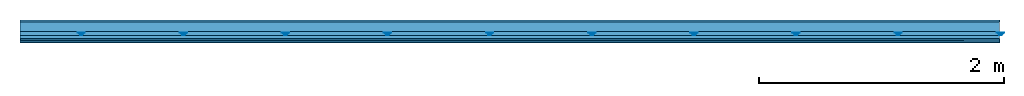
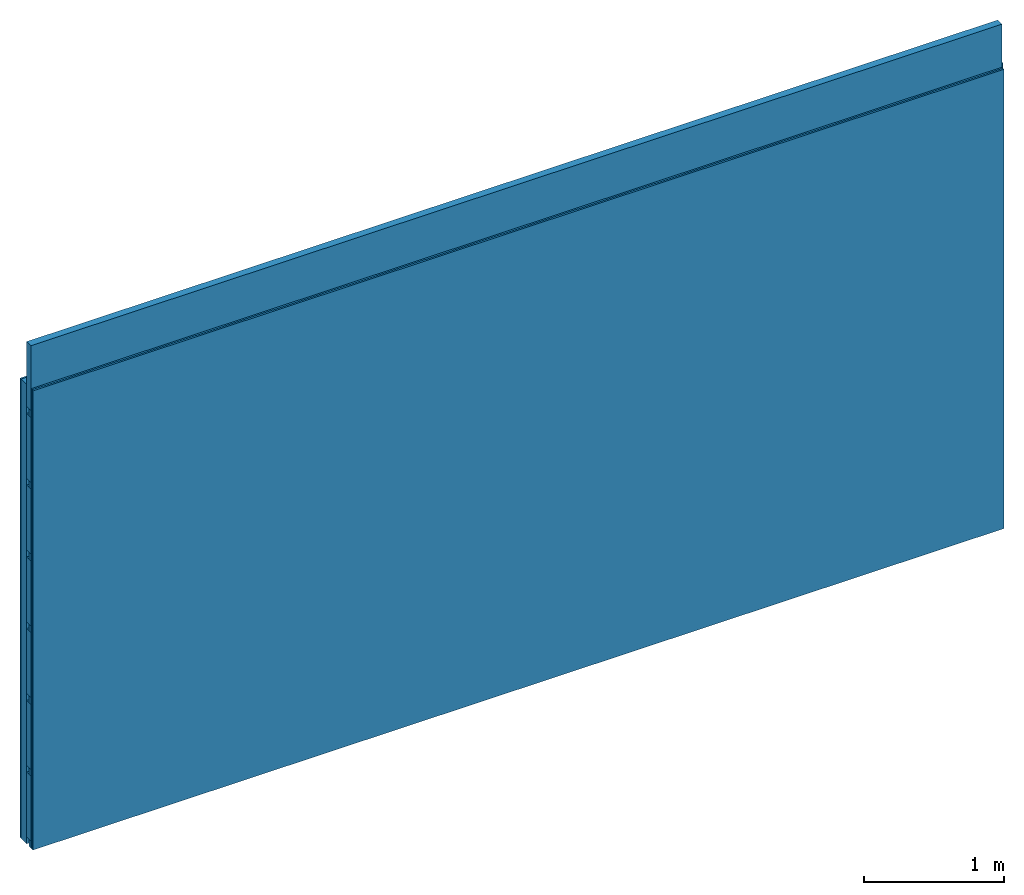
# One storey: 4 members, 3 plates, 1 element without a shape of its own.
"""IFC4 building model written with IfcOpenShell, lengths in metres."""

from ifc_helpers import new_model, si_unit, derived_unit, direction, frame, frame_2d, origin, origin_with_axes, place, context, project, spatial, polyline, rectangle, outline, extrude, material, layer, layer_set, type_object, element, aggregate, save


model = new_model("IFC4")

# Units and contexts
plan_context = context("Plan", 3, precision=1e-05, world=origin(), true_north=direction((0.0, 1.0)))
model_context = context("Model", 3, precision=1e-05, world=origin(), true_north=direction((0.0, 1.0)))
ifc_project = project(units=[si_unit("LENGTHUNIT", "METRE"), derived_unit("SOUNDPRESSUREUNIT", [(si_unit("PRESSUREUNIT", "PASCAL", prefix="MICRO"), 0)]), si_unit("ENERGYUNIT", "JOULE", prefix="MEGA"), si_unit("MASSUNIT", "GRAM", prefix="KILO"), derived_unit("THERMALTRANSMITTANCEUNIT", [(si_unit("POWERUNIT", "WATT"), 1), (si_unit("AREAUNIT", "SQUARE_METRE"), -1), (si_unit("THERMODYNAMICTEMPERATUREUNIT", "KELVIN"), -1)]), derived_unit("AREADENSITYUNIT", [(si_unit("MASSUNIT", "GRAM", prefix="KILO"), 1), (si_unit("AREAUNIT", "SQUARE_METRE"), -1)]), derived_unit("USERDEFINED", [(si_unit("ENERGYUNIT", "JOULE", prefix="MEGA"), 1), (si_unit("AREAUNIT", "SQUARE_METRE"), -1)])], contexts=[plan_context, model_context])

# Site, building, storey
site = spatial("IfcSite", under=ifc_project)
building_placement = place(None, origin())
building = spatial("IfcBuilding", under=site, at=building_placement)
storey_placement = place(building_placement, origin())
storey = spatial("IfcBuildingStorey", under=building, at=storey_placement)

# Wall, members, plates
ifc_material_1 = material(Name="Glued joints")
ifc_layer_1 = layer(ifc_material_1, 0.0, Name="Surface")
ifc_material_2 = material(Category="03.007")
ifc_layer_2 = layer(ifc_material_2, 0.015, Name="1st layer")
ifc_material_3 = material(Name="of the art")
ifc_layer_3 = layer(ifc_material_3, 0.0, Name="Bond")
ifc_layer_4 = layer(None, 0.08, Name="Support")
ifc_material_4 = material(Name="no composite action")
ifc_layer_5 = layer(ifc_material_4, 0.0, Name="Bond")
ifc_layer_6 = layer(None, 0.03, Name="Coupling")
ifc_layer_7 = layer(None, 0.03, Name="Battens / profiles")
ifc_material_5 = material(Name="Plasterboard type A", Category="03.008")
ifc_layer_8 = layer(ifc_material_5, 0.015, Name="Covering 1st layer")
ifc_layer_9 = layer(ifc_material_5, 0.015, Name="Covering 2nd layer")
ifc_material_6 = material(Name="joints", Category="04.017")
ifc_layer_10 = layer(ifc_material_6, 0.0, Name="Surface")
ifc_layer_set = layer_set([ifc_layer_1, ifc_layer_2, ifc_layer_3, ifc_layer_4, ifc_layer_5, ifc_layer_6, ifc_layer_7, ifc_layer_8, ifc_layer_9, ifc_layer_10])
wall_type = type_object("IfcWallType", Name="C0114", PredefinedType="NOTDEFINED", material=ifc_layer_set)
wall_placement = place(None, frame((0.0, 0.0, 0.0), z_axis=(0.0, -1.0, 0.0), x_axis=(1.0, 0.0, 0.0)))
wall = element("IfcWall", 1, at=wall_placement, inside=storey, type_object=wall_type, material=ifc_layer_set, Name="Wall #1")
ifc_material_7 = material()
member_1_placement = place(wall_placement, origin())
member_1 = element("IfcMember", 2, at=member_1_placement, material=ifc_material_7, Name="Support", context=plan_context, shape_type="SweptSolid", body=[
    extrude(rectangle(XDim=1.0, YDim=0.08, at=frame_2d((0.5, 0.04), x_axis=(1.0, 0.0))), frame((0.0, 4.0, 0.015), z_axis=(0.0, -1.0, 0.0), x_axis=(1.0, 0.0, 0.0)), (0.0, 0.0, 1.0), 4.0),
    extrude(rectangle(XDim=1.0, YDim=0.08, at=frame_2d((0.5, 0.04), x_axis=(1.0, 0.0))), frame((1.0, 4.0, 0.015), z_axis=(0.0, -1.0, 0.0), x_axis=(1.0, 0.0, 0.0)), (0.0, 0.0, 1.0), 4.0),
    extrude(rectangle(XDim=1.0, YDim=0.08, at=frame_2d((0.5, 0.04), x_axis=(1.0, 0.0))), frame((2.0, 4.0, 0.015), z_axis=(0.0, -1.0, 0.0), x_axis=(1.0, 0.0, 0.0)), (0.0, 0.0, 1.0), 4.0),
    extrude(rectangle(XDim=1.0, YDim=0.08, at=frame_2d((0.5, 0.04), x_axis=(1.0, 0.0))), frame((3.0, 4.0, 0.015), z_axis=(0.0, -1.0, 0.0), x_axis=(1.0, 0.0, 0.0)), (0.0, 0.0, 1.0), 4.0),
    extrude(rectangle(XDim=1.0, YDim=0.08, at=frame_2d((0.5, 0.04), x_axis=(1.0, 0.0))), frame((4.0, 4.0, 0.015), z_axis=(0.0, -1.0, 0.0), x_axis=(1.0, 0.0, 0.0)), (0.0, 0.0, 1.0), 4.0),
    extrude(rectangle(XDim=1.0, YDim=0.08, at=frame_2d((0.5, 0.04), x_axis=(1.0, 0.0))), frame((5.0, 4.0, 0.015), z_axis=(0.0, -1.0, 0.0), x_axis=(1.0, 0.0, 0.0)), (0.0, 0.0, 1.0), 4.0),
    extrude(rectangle(XDim=1.0, YDim=0.08, at=frame_2d((0.5, 0.04), x_axis=(1.0, 0.0))), frame((6.0, 4.0, 0.015), z_axis=(0.0, -1.0, 0.0), x_axis=(1.0, 0.0, 0.0)), (0.0, 0.0, 1.0), 4.0),
    extrude(rectangle(XDim=1.0, YDim=0.08, at=frame_2d((0.5, 0.04), x_axis=(1.0, 0.0))), frame((7.0, 4.0, 0.015), z_axis=(0.0, -1.0, 0.0), x_axis=(1.0, 0.0, 0.0)), (0.0, 0.0, 1.0), 4.0),
])
ifc_material_8 = material()
member_2_placement = place(wall_placement, origin())
member_2 = element("IfcMember", 3, at=member_2_placement, material=ifc_material_8, Name="Coupling", context=plan_context, shape_type="SweptSolid", body=[
    extrude(outline(polyline([(0.0, 0.0), (0.06, 0.0), (0.04, 0.02), (0.02, 0.02), (0.0, 0.0)])), frame((0.47, 4.0, 0.105), z_axis=(0.0, -1.0, 0.0), x_axis=(1.0, 0.0, 0.0)), (0.0, 0.0, 1.0), 4.0),
    extrude(outline(polyline([(0.0, 0.0), (0.06, 0.0), (0.04, 0.02), (0.02, 0.02), (0.0, 0.0)])), frame((1.304, 4.0, 0.105), z_axis=(0.0, -1.0, 0.0), x_axis=(1.0, 0.0, 0.0)), (0.0, 0.0, 1.0), 4.0),
    extrude(outline(polyline([(0.0, 0.0), (0.06, 0.0), (0.04, 0.02), (0.02, 0.02), (0.0, 0.0)])), frame((2.138, 4.0, 0.105), z_axis=(0.0, -1.0, 0.0), x_axis=(1.0, 0.0, 0.0)), (0.0, 0.0, 1.0), 4.0),
    extrude(outline(polyline([(0.0, 0.0), (0.06, 0.0), (0.04, 0.02), (0.02, 0.02), (0.0, 0.0)])), frame((2.972, 4.0, 0.105), z_axis=(0.0, -1.0, 0.0), x_axis=(1.0, 0.0, 0.0)), (0.0, 0.0, 1.0), 4.0),
    extrude(outline(polyline([(0.0, 0.0), (0.06, 0.0), (0.04, 0.02), (0.02, 0.02), (0.0, 0.0)])), frame((3.806, 4.0, 0.105), z_axis=(0.0, -1.0, 0.0), x_axis=(1.0, 0.0, 0.0)), (0.0, 0.0, 1.0), 4.0),
    extrude(outline(polyline([(0.0, 0.0), (0.06, 0.0), (0.04, 0.02), (0.02, 0.02), (0.0, 0.0)])), frame((4.64, 4.0, 0.105), z_axis=(0.0, -1.0, 0.0), x_axis=(1.0, 0.0, 0.0)), (0.0, 0.0, 1.0), 4.0),
    extrude(outline(polyline([(0.0, 0.0), (0.06, 0.0), (0.04, 0.02), (0.02, 0.02), (0.0, 0.0)])), frame((5.474, 4.0, 0.105), z_axis=(0.0, -1.0, 0.0), x_axis=(1.0, 0.0, 0.0)), (0.0, 0.0, 1.0), 4.0),
    extrude(outline(polyline([(0.0, 0.0), (0.06, 0.0), (0.04, 0.02), (0.02, 0.02), (0.0, 0.0)])), frame((6.308, 4.0, 0.105), z_axis=(0.0, -1.0, 0.0), x_axis=(1.0, 0.0, 0.0)), (0.0, 0.0, 1.0), 4.0),
    extrude(outline(polyline([(0.0, 0.0), (0.06, 0.0), (0.04, 0.02), (0.02, 0.02), (0.0, 0.0)])), frame((7.142, 4.0, 0.105), z_axis=(0.0, -1.0, 0.0), x_axis=(1.0, 0.0, 0.0)), (0.0, 0.0, 1.0), 4.0),
    extrude(outline(polyline([(0.0, 0.0), (0.06, 0.0), (0.04, 0.02), (0.02, 0.02), (0.0, 0.0)])), frame((7.976, 4.0, 0.105), z_axis=(0.0, -1.0, 0.0), x_axis=(1.0, 0.0, 0.0)), (0.0, 0.0, 1.0), 4.0),
])
member_3_placement = place(wall_placement, origin())
member_3 = element("IfcMember", 4, at=member_3_placement, material=ifc_material_8, Name="Battens / profiles", context=plan_context, shape_type="SweptSolid", body=[
    extrude(rectangle(XDim=0.06, YDim=0.03, at=frame_2d((0.03, 0.015), x_axis=(1.0, 0.0))), frame((0.0, 0.0, 0.125), z_axis=(1.0, 0.0, 0.0), x_axis=(0.0, 1.0, 0.0)), (0.0, 0.0, 1.0), 8.0),
    extrude(rectangle(XDim=0.06, YDim=0.03, at=frame_2d((0.03, 0.015), x_axis=(1.0, 0.0))), frame((0.0, 0.625, 0.125), z_axis=(1.0, 0.0, 0.0), x_axis=(0.0, 1.0, 0.0)), (0.0, 0.0, 1.0), 8.0),
    extrude(rectangle(XDim=0.06, YDim=0.03, at=frame_2d((0.03, 0.015), x_axis=(1.0, 0.0))), frame((0.0, 1.25, 0.125), z_axis=(1.0, 0.0, 0.0), x_axis=(0.0, 1.0, 0.0)), (0.0, 0.0, 1.0), 8.0),
    extrude(rectangle(XDim=0.06, YDim=0.03, at=frame_2d((0.03, 0.015), x_axis=(1.0, 0.0))), frame((0.0, 1.875, 0.125), z_axis=(1.0, 0.0, 0.0), x_axis=(0.0, 1.0, 0.0)), (0.0, 0.0, 1.0), 8.0),
    extrude(rectangle(XDim=0.06, YDim=0.03, at=frame_2d((0.03, 0.015), x_axis=(1.0, 0.0))), frame((0.0, 2.5, 0.125), z_axis=(1.0, 0.0, 0.0), x_axis=(0.0, 1.0, 0.0)), (0.0, 0.0, 1.0), 8.0),
    extrude(rectangle(XDim=0.06, YDim=0.03, at=frame_2d((0.03, 0.015), x_axis=(1.0, 0.0))), frame((0.0, 3.125, 0.125), z_axis=(1.0, 0.0, 0.0), x_axis=(0.0, 1.0, 0.0)), (0.0, 0.0, 1.0), 8.0),
    extrude(rectangle(XDim=0.06, YDim=0.03, at=frame_2d((0.03, 0.015), x_axis=(1.0, 0.0))), frame((0.0, 3.75, 0.125), z_axis=(1.0, 0.0, 0.0), x_axis=(0.0, 1.0, 0.0)), (0.0, 0.0, 1.0), 8.0),
])
ifc_material_9 = material()
member_4_placement = place(wall_placement, origin())
member_4 = element("IfcMember", 5, at=member_4_placement, material=ifc_material_9, Name="Cavity", context=plan_context, shape_type="SweptSolid", body=[
    extrude(rectangle(XDim=0.565, YDim=0.06, at=frame_2d((0.2825, 0.03), x_axis=(1.0, 0.0))), frame((0.0, 0.06, 0.095), z_axis=(1.0, 0.0, 0.0), x_axis=(0.0, 1.0, 0.0)), (0.0, 0.0, 1.0), 8.0),
    extrude(rectangle(XDim=0.565, YDim=0.06, at=frame_2d((0.2825, 0.03), x_axis=(1.0, 0.0))), frame((0.0, 0.685, 0.095), z_axis=(1.0, 0.0, 0.0), x_axis=(0.0, 1.0, 0.0)), (0.0, 0.0, 1.0), 8.0),
    extrude(rectangle(XDim=0.565, YDim=0.06, at=frame_2d((0.2825, 0.03), x_axis=(1.0, 0.0))), frame((0.0, 1.31, 0.095), z_axis=(1.0, 0.0, 0.0), x_axis=(0.0, 1.0, 0.0)), (0.0, 0.0, 1.0), 8.0),
    extrude(rectangle(XDim=0.565, YDim=0.06, at=frame_2d((0.2825, 0.03), x_axis=(1.0, 0.0))), frame((0.0, 1.935, 0.095), z_axis=(1.0, 0.0, 0.0), x_axis=(0.0, 1.0, 0.0)), (0.0, 0.0, 1.0), 8.0),
    extrude(rectangle(XDim=0.565, YDim=0.06, at=frame_2d((0.2825, 0.03), x_axis=(1.0, 0.0))), frame((0.0, 2.56, 0.095), z_axis=(1.0, 0.0, 0.0), x_axis=(0.0, 1.0, 0.0)), (0.0, 0.0, 1.0), 8.0),
    extrude(rectangle(XDim=0.565, YDim=0.06, at=frame_2d((0.2825, 0.03), x_axis=(1.0, 0.0))), frame((0.0, 3.185, 0.095), z_axis=(1.0, 0.0, 0.0), x_axis=(0.0, 1.0, 0.0)), (0.0, 0.0, 1.0), 8.0),
    extrude(rectangle(XDim=0.565, YDim=0.06, at=frame_2d((0.2825, 0.03), x_axis=(1.0, 0.0))), frame((0.0, 3.81, 0.095), z_axis=(1.0, 0.0, 0.0), x_axis=(0.0, 1.0, 0.0)), (0.0, 0.0, 1.0), 8.0),
])
plate_1_placement = place(wall_placement, origin())
plate_1 = element("IfcPlate", 6, at=plate_1_placement, material=ifc_material_2, Name="1st layer", context=plan_context, shape_type="SweptSolid", body=[
    extrude(rectangle(XDim=8.0, YDim=4.0, at=frame_2d((4.0, 2.0), x_axis=(1.0, 0.0))), origin_with_axes(), (0.0, 0.0, 1.0), 0.015),
])
plate_2_placement = place(wall_placement, origin())
plate_2 = element("IfcPlate", 7, at=plate_2_placement, material=ifc_material_5, Name="Covering 1st layer", context=plan_context, shape_type="SweptSolid", body=[
    extrude(rectangle(XDim=8.0, YDim=4.0, at=frame_2d((4.0, 2.0), x_axis=(1.0, 0.0))), frame((0.0, 0.0, 0.155), z_axis=(0.0, 0.0, 1.0), x_axis=(1.0, 0.0, 0.0)), (0.0, 0.0, 1.0), 0.015),
])
plate_3_placement = place(wall_placement, origin())
plate_3 = element("IfcPlate", 8, at=plate_3_placement, material=ifc_material_5, Name="Covering 2nd layer", context=plan_context, shape_type="SweptSolid", body=[
    extrude(rectangle(XDim=8.0, YDim=4.0, at=frame_2d((4.0, 2.0), x_axis=(1.0, 0.0))), frame((0.0, 0.0, 0.17), z_axis=(0.0, 0.0, 1.0), x_axis=(1.0, 0.0, 0.0)), (0.0, 0.0, 1.0), 0.015),
])
aggregate(wall, [plate_1, member_1, member_2, member_3, member_4, plate_2, plate_3])

save(model, "model.ifc")
